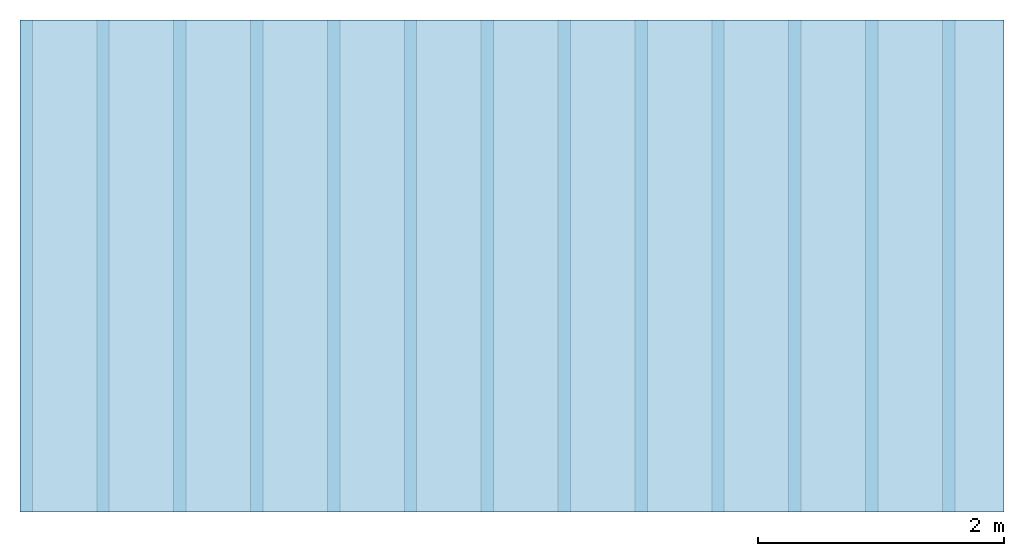
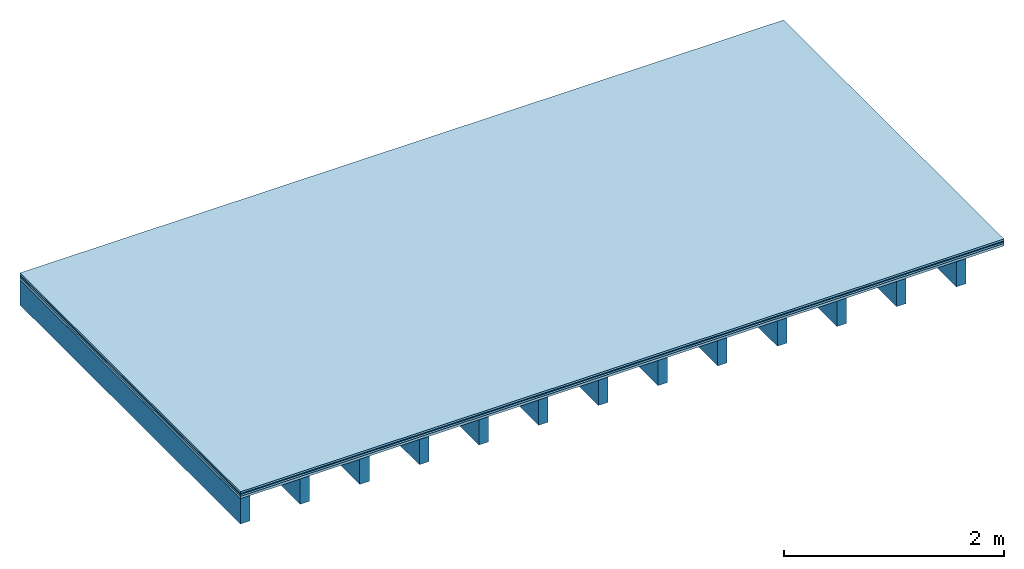
# One storey: 4 plates, 1 member, 1 element without a shape of its own.
"""IFC4 building model written with IfcOpenShell, lengths in metres."""

from ifc_helpers import new_model, si_unit, derived_unit, direction, frame, frame_2d, origin, origin_with_axes, place, context, project, spatial, rectangle, extrude, material, layer, layer_set, type_object, element, aggregate, save


model = new_model("IFC4")

# Units and contexts
plan_context = context("Plan", 3, precision=1e-05, world=origin(), true_north=direction((0.0, 1.0)))
model_context = context("Model", 3, precision=1e-05, world=origin(), true_north=direction((0.0, 1.0)))
ifc_project = project(units=[si_unit("LENGTHUNIT", "METRE"), derived_unit("SOUNDPRESSUREUNIT", [(si_unit("PRESSUREUNIT", "PASCAL", prefix="MICRO"), 0)]), si_unit("ENERGYUNIT", "JOULE", prefix="MEGA"), si_unit("MASSUNIT", "GRAM", prefix="KILO"), derived_unit("THERMALTRANSMITTANCEUNIT", [(si_unit("POWERUNIT", "WATT"), 1), (si_unit("AREAUNIT", "SQUARE_METRE"), -1), (si_unit("THERMODYNAMICTEMPERATUREUNIT", "KELVIN"), -1)]), derived_unit("AREADENSITYUNIT", [(si_unit("MASSUNIT", "GRAM", prefix="KILO"), 1), (si_unit("AREAUNIT", "SQUARE_METRE"), -1)]), derived_unit("USERDEFINED", [(si_unit("ENERGYUNIT", "JOULE", prefix="MEGA"), 1), (si_unit("AREAUNIT", "SQUARE_METRE"), -1)])], contexts=[plan_context, model_context])

# Site, building, storey
site = spatial("IfcSite", under=ifc_project)
building_placement = place(None, origin())
building = spatial("IfcBuilding", under=site, at=building_placement)
storey_placement = place(building_placement, origin())
storey = spatial("IfcBuildingStorey", under=building, at=storey_placement)

# Slab, member, plates
ifc_material_1 = material(Name="clay", Category="02.004")
ifc_layer_1 = layer(ifc_material_1, 0.02, Name="Use and protection layer 2")
ifc_material_2 = material(Name="Protective layer", Category="09.007")
ifc_layer_2 = layer(ifc_material_2, 0.01, Name="Use and protection layer 1")
ifc_material_3 = material(Name="Bituminous", Category="09.003")
ifc_layer_3 = layer(ifc_material_3, 0.02, Name="Seal")
ifc_material_4 = material(Name="3-layer panels", Category="07.001")
ifc_layer_4 = layer(ifc_material_4, 0.027, Name="above 2nd layer")
ifc_material_5 = material(Name="no composite action")
ifc_layer_5 = layer(ifc_material_5, 0.0, Name="Bond")
ifc_layer_6 = layer(None, 0.28, Name="Support")
ifc_layer_set = layer_set([ifc_layer_1, ifc_layer_2, ifc_layer_3, ifc_layer_4, ifc_layer_5, ifc_layer_6])
slab_type = type_object("IfcSlabType", Name="F0100", PredefinedType="NOTDEFINED", material=ifc_layer_set)
slab_placement = place(None, frame((0.0, 0.0, 0.0), z_axis=(0.0, 0.0, -1.0), x_axis=(1.0, 0.0, 0.0)))
slab = element("IfcSlab", 1, at=slab_placement, inside=storey, type_object=slab_type, material=ifc_layer_set, Name="Slab #1")
ifc_material_6 = material()
member_placement = place(slab_placement, origin())
member = element("IfcMember", 2, at=member_placement, material=ifc_material_6, Name="Support", context=plan_context, shape_type="SweptSolid", body=[
    extrude(rectangle(XDim=0.1, YDim=0.28, at=frame_2d((0.05, 0.14), x_axis=(1.0, 0.0))), frame((0.0, 4.0, 0.077), z_axis=(0.0, -1.0, 0.0), x_axis=(1.0, 0.0, 0.0)), (0.0, 0.0, 1.0), 4.0),
    extrude(rectangle(XDim=0.1, YDim=0.28, at=frame_2d((0.05, 0.14), x_axis=(1.0, 0.0))), frame((0.625, 4.0, 0.077), z_axis=(0.0, -1.0, 0.0), x_axis=(1.0, 0.0, 0.0)), (0.0, 0.0, 1.0), 4.0),
    extrude(rectangle(XDim=0.1, YDim=0.28, at=frame_2d((0.05, 0.14), x_axis=(1.0, 0.0))), frame((1.25, 4.0, 0.077), z_axis=(0.0, -1.0, 0.0), x_axis=(1.0, 0.0, 0.0)), (0.0, 0.0, 1.0), 4.0),
    extrude(rectangle(XDim=0.1, YDim=0.28, at=frame_2d((0.05, 0.14), x_axis=(1.0, 0.0))), frame((1.875, 4.0, 0.077), z_axis=(0.0, -1.0, 0.0), x_axis=(1.0, 0.0, 0.0)), (0.0, 0.0, 1.0), 4.0),
    extrude(rectangle(XDim=0.1, YDim=0.28, at=frame_2d((0.05, 0.14), x_axis=(1.0, 0.0))), frame((2.5, 4.0, 0.077), z_axis=(0.0, -1.0, 0.0), x_axis=(1.0, 0.0, 0.0)), (0.0, 0.0, 1.0), 4.0),
    extrude(rectangle(XDim=0.1, YDim=0.28, at=frame_2d((0.05, 0.14), x_axis=(1.0, 0.0))), frame((3.125, 4.0, 0.077), z_axis=(0.0, -1.0, 0.0), x_axis=(1.0, 0.0, 0.0)), (0.0, 0.0, 1.0), 4.0),
    extrude(rectangle(XDim=0.1, YDim=0.28, at=frame_2d((0.05, 0.14), x_axis=(1.0, 0.0))), frame((3.75, 4.0, 0.077), z_axis=(0.0, -1.0, 0.0), x_axis=(1.0, 0.0, 0.0)), (0.0, 0.0, 1.0), 4.0),
    extrude(rectangle(XDim=0.1, YDim=0.28, at=frame_2d((0.05, 0.14), x_axis=(1.0, 0.0))), frame((4.375, 4.0, 0.077), z_axis=(0.0, -1.0, 0.0), x_axis=(1.0, 0.0, 0.0)), (0.0, 0.0, 1.0), 4.0),
    extrude(rectangle(XDim=0.1, YDim=0.28, at=frame_2d((0.05, 0.14), x_axis=(1.0, 0.0))), frame((5.0, 4.0, 0.077), z_axis=(0.0, -1.0, 0.0), x_axis=(1.0, 0.0, 0.0)), (0.0, 0.0, 1.0), 4.0),
    extrude(rectangle(XDim=0.1, YDim=0.28, at=frame_2d((0.05, 0.14), x_axis=(1.0, 0.0))), frame((5.625, 4.0, 0.077), z_axis=(0.0, -1.0, 0.0), x_axis=(1.0, 0.0, 0.0)), (0.0, 0.0, 1.0), 4.0),
    extrude(rectangle(XDim=0.1, YDim=0.28, at=frame_2d((0.05, 0.14), x_axis=(1.0, 0.0))), frame((6.25, 4.0, 0.077), z_axis=(0.0, -1.0, 0.0), x_axis=(1.0, 0.0, 0.0)), (0.0, 0.0, 1.0), 4.0),
    extrude(rectangle(XDim=0.1, YDim=0.28, at=frame_2d((0.05, 0.14), x_axis=(1.0, 0.0))), frame((6.875, 4.0, 0.077), z_axis=(0.0, -1.0, 0.0), x_axis=(1.0, 0.0, 0.0)), (0.0, 0.0, 1.0), 4.0),
    extrude(rectangle(XDim=0.1, YDim=0.28, at=frame_2d((0.05, 0.14), x_axis=(1.0, 0.0))), frame((7.5, 4.0, 0.077), z_axis=(0.0, -1.0, 0.0), x_axis=(1.0, 0.0, 0.0)), (0.0, 0.0, 1.0), 4.0),
])
plate_1_placement = place(slab_placement, origin())
plate_1 = element("IfcPlate", 3, at=plate_1_placement, material=ifc_material_1, Name="Use and protection layer 2", context=plan_context, shape_type="SweptSolid", body=[
    extrude(rectangle(XDim=8.0, YDim=4.0, at=frame_2d((4.0, 2.0), x_axis=(1.0, 0.0))), origin_with_axes(), (0.0, 0.0, 1.0), 0.02),
])
plate_2_placement = place(slab_placement, origin())
plate_2 = element("IfcPlate", 4, at=plate_2_placement, material=ifc_material_2, Name="Use and protection layer 1", context=plan_context, shape_type="SweptSolid", body=[
    extrude(rectangle(XDim=8.0, YDim=4.0, at=frame_2d((4.0, 2.0), x_axis=(1.0, 0.0))), frame((0.0, 0.0, 0.02), z_axis=(0.0, 0.0, 1.0), x_axis=(1.0, 0.0, 0.0)), (0.0, 0.0, 1.0), 0.01),
])
plate_3_placement = place(slab_placement, origin())
plate_3 = element("IfcPlate", 5, at=plate_3_placement, material=ifc_material_3, Name="Seal", context=plan_context, shape_type="SweptSolid", body=[
    extrude(rectangle(XDim=8.0, YDim=4.0, at=frame_2d((4.0, 2.0), x_axis=(1.0, 0.0))), frame((0.0, 0.0, 0.03), z_axis=(0.0, 0.0, 1.0), x_axis=(1.0, 0.0, 0.0)), (0.0, 0.0, 1.0), 0.02),
])
plate_4_placement = place(slab_placement, origin())
plate_4 = element("IfcPlate", 6, at=plate_4_placement, material=ifc_material_4, Name="above 2nd layer", context=plan_context, shape_type="SweptSolid", body=[
    extrude(rectangle(XDim=8.0, YDim=4.0, at=frame_2d((4.0, 2.0), x_axis=(1.0, 0.0))), frame((0.0, 0.0, 0.05), z_axis=(0.0, 0.0, 1.0), x_axis=(1.0, 0.0, 0.0)), (0.0, 0.0, 1.0), 0.027),
])
aggregate(slab, [plate_1, plate_2, plate_3, plate_4, member])

save(model, "model.ifc")
